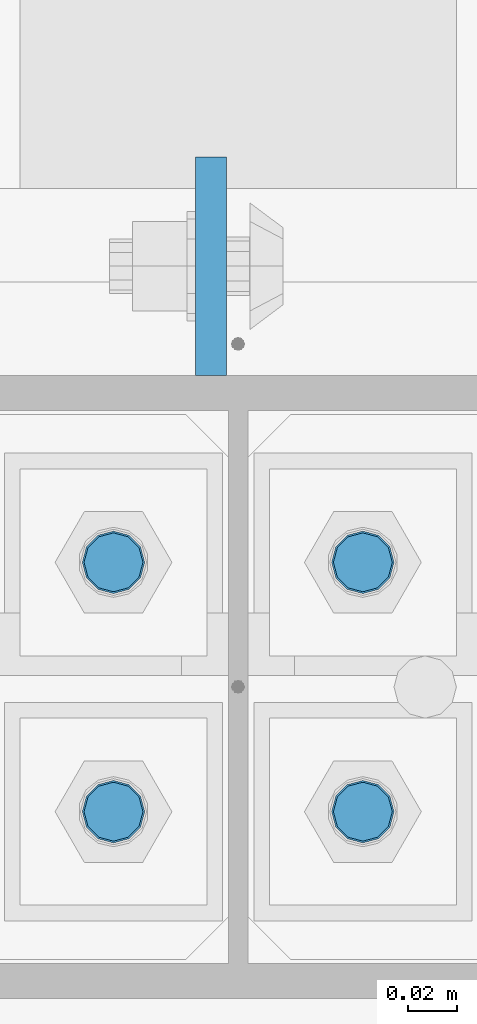
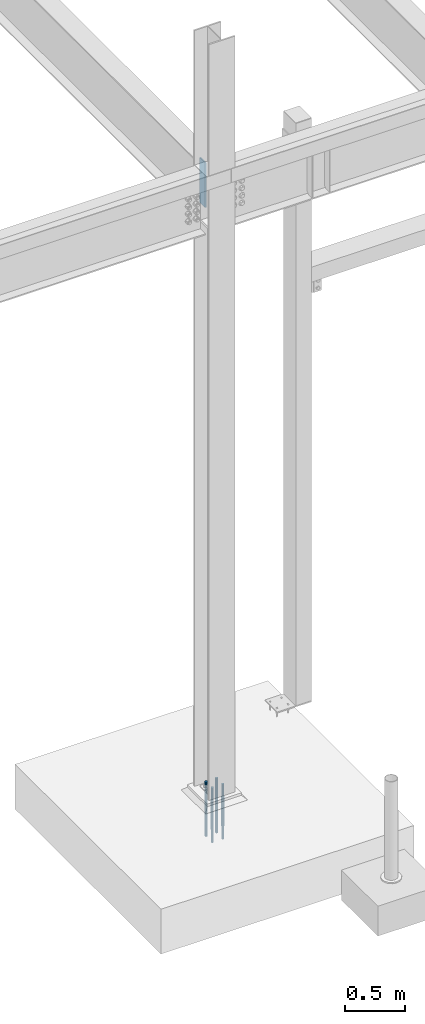
# One storey, part 1561 of 3843: 5 columns, 2 elements without a shape of their own.
"""IFC2X3 building model written with IfcOpenShell, lengths in millimetres."""

from ifc_helpers import new_model, si_unit, frame, origin_with_axes, place, context, subcontext, project, spatial, faceted_brep, material, type_object, element, aggregate, save


model = new_model("IFC2X3")

# Units and contexts
model_context = context("Model", 3, precision=1e-05, world=origin_with_axes())
body_context = subcontext(model_context, "Body", "Model", "MODEL_VIEW")
ifc_project = project(units=[si_unit("LENGTHUNIT", "METRE", prefix="MILLI"), si_unit("AREAUNIT", "SQUARE_METRE"), si_unit("VOLUMEUNIT", "CUBIC_METRE"), si_unit("MASSUNIT", "GRAM", prefix="KILO"), si_unit("TIMEUNIT", "SECOND"), si_unit("PLANEANGLEUNIT", "RADIAN"), si_unit("SOLIDANGLEUNIT", "STERADIAN"), si_unit("THERMODYNAMICTEMPERATUREUNIT", "DEGREE_CELSIUS"), si_unit("LUMINOUSINTENSITYUNIT", "LUMEN")], contexts=[model_context])

# Site, building, storey
site_placement = place(None, origin_with_axes())
site = spatial("IfcSite", under=ifc_project, at=site_placement, CompositionType="ELEMENT")
building_placement = place(site_placement, origin_with_axes())
building = spatial("IfcBuilding", under=site, at=building_placement, Name="Undefined", CompositionType="ELEMENT")
storey_placement = place(building_placement, origin_with_axes())
storey = spatial("IfcBuildingStorey", under=building, at=storey_placement, Name="Undefined", CompositionType="ELEMENT", Elevation=0.0)

# Assembly, columns
assembly_1_placement = place(storey_placement, origin_with_axes())
assembly_1 = element("IfcElementAssembly", 1, at=assembly_1_placement, inside=storey, Name="TEMPLATE", AssemblyPlace="NOTDEFINED", PredefinedType="RIGID_FRAME")
ifc_material_1 = material(Name="Undefined/F1554-GR.55")
column_type_1 = type_object("IfcColumnType", PredefinedType="NOTDEFINED")
column_1_placement = place(assembly_1_placement, frame((15189.2, 89065.1, 30022.8), z_axis=(0.0, -1.0, 0.0), x_axis=(0.0, 0.0, -1.0)))
column_1 = element("IfcColumn", 2, at=column_1_placement, type_object=column_type_1, material=ifc_material_1, Name="ANCHOR_ROD", context=body_context, shape_type="Brep", body=[
    faceted_brep([(-127.0, -10.3923048454162, 6.0), (-127.0, -6.0, 10.3923048454126), (-127.0, 0.0, 12.0), (-127.0, 6.0, 10.3923048454126), (-127.0, 10.3923048454162, 6.0), (-127.0, 12.0, 0.0), (-127.0, 10.3923048454162, -6.0), (-127.0, 6.0, -10.3923048454126), (-127.0, 0.0, -12.0), (-127.0, -6.0, -10.3923048454126), (-127.0, -10.3923048454162, -6.0), (-127.0, -12.0, 0.0), (0.0, 12.0, 0.0), (0.0, 10.3923048454162, -6.0), (0.0, 6.0, -10.3923048454126), (0.0, 0.0, -12.0), (0.0, -6.0, -10.3923048454126), (0.0, -10.3923048454162, -6.0), (0.0, -12.0, 0.0), (0.0, -10.3923048454162, 6.0), (0.0, -6.0, 10.3923048454126), (0.0, 0.0, 12.0), (0.0, 6.0, 10.3923048454126), (0.0, 10.3923048454162, 6.0), (0.0, -10.9985226280696, 6.34999999999854), (0.0, -6.35000000000582, 10.9985226280623), (0.0, 0.0, 12.6999999999971), (0.0, 6.35000000000582, 10.9985226280623), (0.0, 10.9985226280696, 6.34999999999854), (0.0, 12.6999999999971, 0.0), (0.0, 10.9985226280696, -6.34999999999854), (0.0, 6.35000000000582, -10.9985226280623), (0.0, 0.0, -12.6999999999971), (0.0, -6.35000000000582, -10.9985226280623), (0.0, -10.9985226280696, -6.34999999999854), (0.0, -12.6999999999971, 0.0), (304.799999999999, -12.6999999999971, 0.0), (304.799999999999, -10.9985226280623, 6.35000000000036), (304.799999999999, -6.34999999999854, 10.9985226280623), (304.799999999999, 0.0, 12.7000000000007), (304.799999999999, 6.34999999999854, 10.9985226280623), (304.799999999999, 10.9985226280623, 6.35000000000036), (304.799999999999, 12.6999999999971, 0.0), (304.799999999999, 10.9985226280623, -6.35000000000036), (304.799999999999, 6.34999999999854, -10.9985226280623), (304.799999999999, 0.0, -12.7000000000007), (304.799999999999, -6.34999999999854, -10.9985226280623), (304.799999999999, -10.9985226280623, -6.35000000000036), (304.799999999999, -6.0, 10.3923048454126), (304.799999999999, 0.0, 12.0), (304.799999999999, 6.0, 10.3923048454126), (304.799999999999, 10.3923048454162, 6.0), (304.799999999999, 12.0, 0.0), (304.799999999999, 10.3923048454162, -6.0), (304.799999999999, 6.0, -10.3923048454126), (304.799999999999, 0.0, -12.0), (304.799999999999, -6.0, -10.3923048454126), (304.799999999999, -10.3923048454162, -6.0), (304.799999999999, -12.0, 0.0), (304.799999999999, -10.3923048454162, 6.0), (431.799999999999, -6.0, -10.3923048454126), (431.799999999999, 0.0, -12.0), (431.799999999999, 6.0, -10.3923048454126), (431.799999999999, 10.3923048454162, -6.0), (431.799999999999, 12.0, 0.0), (431.799999999999, 10.3923048454162, 6.0), (431.799999999999, 6.0, 10.3923048454126), (431.799999999999, 0.0, 12.0), (431.799999999999, -6.0, 10.3923048454126), (431.799999999999, -10.3923048454162, 6.0), (431.799999999999, -12.0, 0.0), (431.799999999999, -10.3923048454162, -6.0)], [[[0, 1, 2, 3, 4, 5, 6, 7, 8, 9, 10, 11]], [[6, 5, 12, 13]], [[7, 6, 13, 14]], [[8, 7, 14, 15]], [[9, 8, 15, 16]], [[10, 9, 16, 17]], [[11, 10, 17, 18]], [[0, 11, 18, 19]], [[1, 0, 19, 20]], [[2, 1, 20, 21]], [[3, 2, 21, 22]], [[4, 3, 22, 23]], [[5, 4, 23, 12]], [[24, 25, 26, 27, 28, 29, 30, 31, 32, 33, 34, 35], [22, 21, 20, 19, 18, 17, 16, 15, 14, 13, 12, 23]], [[24, 35, 36, 37]], [[25, 24, 37, 38]], [[26, 25, 38, 39]], [[27, 26, 39, 40]], [[28, 27, 40, 41]], [[29, 28, 41, 42]], [[30, 29, 42, 43]], [[31, 30, 43, 44]], [[32, 31, 44, 45]], [[33, 32, 45, 46]], [[34, 33, 46, 47]], [[35, 34, 47, 36]], [[46, 45, 44, 43, 42, 41, 40, 39, 38, 37, 36, 47], [48, 49, 50, 51, 52, 53, 54, 55, 56, 57, 58, 59]], [[60, 61, 62, 63, 64, 65, 66, 67, 68, 69, 70, 71]], [[68, 67, 49, 48]], [[69, 68, 48, 59]], [[70, 69, 59, 58]], [[71, 70, 58, 57]], [[60, 71, 57, 56]], [[61, 60, 56, 55]], [[62, 61, 55, 54]], [[63, 62, 54, 53]], [[64, 63, 53, 52]], [[65, 64, 52, 51]], [[66, 65, 51, 50]], [[67, 66, 50, 49]]]),
])
column_2_placement = place(assembly_1_placement, frame((15290.8, 89065.1, 30022.8), z_axis=(0.0, 1.0, 0.0), x_axis=(0.0, 0.0, -1.0)))
column_2 = element("IfcColumn", 3, at=column_2_placement, type_object=column_type_1, material=ifc_material_1, Name="ANCHOR_ROD", context=body_context, shape_type="Brep", body=[
    faceted_brep([(-127.0, -10.3923048454162, 6.0), (-127.0, -6.0, 10.3923048454126), (-127.0, 0.0, 12.0), (-127.0, 6.0, 10.3923048454126), (-127.0, 10.3923048454162, 6.0), (-127.0, 12.0, 0.0), (-127.0, 10.3923048454162, -6.0), (-127.0, 6.0, -10.3923048454126), (-127.0, 0.0, -12.0), (-127.0, -6.0, -10.3923048454126), (-127.0, -10.3923048454162, -6.0), (-127.0, -12.0, 0.0), (0.0, 12.0, 0.0), (0.0, 10.3923048454162, -6.0), (0.0, 6.0, -10.3923048454126), (0.0, 0.0, -12.0), (0.0, -6.0, -10.3923048454126), (0.0, -10.3923048454162, -6.0), (0.0, -12.0, 0.0), (0.0, -10.3923048454162, 6.0), (0.0, -6.0, 10.3923048454126), (0.0, 0.0, 12.0), (0.0, 6.0, 10.3923048454126), (0.0, 10.3923048454162, 6.0), (0.0, -10.9985226280696, 6.34999999999854), (0.0, -6.35000000000582, 10.9985226280623), (0.0, 0.0, 12.6999999999971), (0.0, 6.35000000000582, 10.9985226280623), (0.0, 10.9985226280696, 6.34999999999854), (0.0, 12.6999999999971, 0.0), (0.0, 10.9985226280696, -6.34999999999854), (0.0, 6.35000000000582, -10.9985226280623), (0.0, 0.0, -12.6999999999971), (0.0, -6.35000000000582, -10.9985226280623), (0.0, -10.9985226280696, -6.34999999999854), (0.0, -12.6999999999971, 0.0), (304.799999999999, -12.6999999999971, 0.0), (304.799999999999, -10.9985226280623, 6.35000000000036), (304.799999999999, -6.34999999999854, 10.9985226280623), (304.799999999999, 0.0, 12.7000000000007), (304.799999999999, 6.34999999999854, 10.9985226280623), (304.799999999999, 10.9985226280623, 6.35000000000036), (304.799999999999, 12.6999999999971, 0.0), (304.799999999999, 10.9985226280623, -6.35000000000036), (304.799999999999, 6.34999999999854, -10.9985226280623), (304.799999999999, 0.0, -12.7000000000007), (304.799999999999, -6.34999999999854, -10.9985226280623), (304.799999999999, -10.9985226280623, -6.35000000000036), (304.799999999999, -6.0, 10.3923048454126), (304.799999999999, 0.0, 12.0), (304.799999999999, 6.0, 10.3923048454126), (304.799999999999, 10.3923048454162, 6.0), (304.799999999999, 12.0, 0.0), (304.799999999999, 10.3923048454162, -6.0), (304.799999999999, 6.0, -10.3923048454126), (304.799999999999, 0.0, -12.0), (304.799999999999, -6.0, -10.3923048454126), (304.799999999999, -10.3923048454162, -6.0), (304.799999999999, -12.0, 0.0), (304.799999999999, -10.3923048454162, 6.0), (431.799999999999, -6.0, -10.3923048454126), (431.799999999999, 0.0, -12.0), (431.799999999999, 6.0, -10.3923048454126), (431.799999999999, 10.3923048454162, -6.0), (431.799999999999, 12.0, 0.0), (431.799999999999, 10.3923048454162, 6.0), (431.799999999999, 6.0, 10.3923048454126), (431.799999999999, 0.0, 12.0), (431.799999999999, -6.0, 10.3923048454126), (431.799999999999, -10.3923048454162, 6.0), (431.799999999999, -12.0, 0.0), (431.799999999999, -10.3923048454162, -6.0)], [[[0, 1, 2, 3, 4, 5, 6, 7, 8, 9, 10, 11]], [[6, 5, 12, 13]], [[7, 6, 13, 14]], [[8, 7, 14, 15]], [[9, 8, 15, 16]], [[10, 9, 16, 17]], [[11, 10, 17, 18]], [[0, 11, 18, 19]], [[1, 0, 19, 20]], [[2, 1, 20, 21]], [[3, 2, 21, 22]], [[4, 3, 22, 23]], [[5, 4, 23, 12]], [[24, 25, 26, 27, 28, 29, 30, 31, 32, 33, 34, 35], [22, 21, 20, 19, 18, 17, 16, 15, 14, 13, 12, 23]], [[24, 35, 36, 37]], [[25, 24, 37, 38]], [[26, 25, 38, 39]], [[27, 26, 39, 40]], [[28, 27, 40, 41]], [[29, 28, 41, 42]], [[30, 29, 42, 43]], [[31, 30, 43, 44]], [[32, 31, 44, 45]], [[33, 32, 45, 46]], [[34, 33, 46, 47]], [[35, 34, 47, 36]], [[46, 45, 44, 43, 42, 41, 40, 39, 38, 37, 36, 47], [48, 49, 50, 51, 52, 53, 54, 55, 56, 57, 58, 59]], [[60, 61, 62, 63, 64, 65, 66, 67, 68, 69, 70, 71]], [[68, 67, 49, 48]], [[69, 68, 48, 59]], [[70, 69, 59, 58]], [[71, 70, 58, 57]], [[60, 71, 57, 56]], [[61, 60, 56, 55]], [[62, 61, 55, 54]], [[63, 62, 54, 53]], [[64, 63, 53, 52]], [[65, 64, 52, 51]], [[66, 65, 51, 50]], [[67, 66, 50, 49]]]),
])
column_3_placement = place(assembly_1_placement, frame((15189.2, 89166.7, 30022.8), z_axis=(0.0, -1.0, 0.0), x_axis=(0.0, 0.0, -1.0)))
column_3 = element("IfcColumn", 4, at=column_3_placement, type_object=column_type_1, material=ifc_material_1, Name="ANCHOR_ROD", context=body_context, shape_type="Brep", body=[
    faceted_brep([(-127.0, -10.3923048454162, 6.0), (-127.0, -6.0, 10.3923048454126), (-127.0, 0.0, 12.0), (-127.0, 6.0, 10.3923048454126), (-127.0, 10.3923048454162, 6.0), (-127.0, 12.0, 0.0), (-127.0, 10.3923048454162, -6.0), (-127.0, 6.0, -10.3923048454126), (-127.0, 0.0, -12.0), (-127.0, -6.0, -10.3923048454126), (-127.0, -10.3923048454162, -6.0), (-127.0, -12.0, 0.0), (0.0, 12.0, 0.0), (0.0, 10.3923048454162, -6.0), (0.0, 6.0, -10.3923048454126), (0.0, 0.0, -12.0), (0.0, -6.0, -10.3923048454126), (0.0, -10.3923048454162, -6.0), (0.0, -12.0, 0.0), (0.0, -10.3923048454162, 6.0), (0.0, -6.0, 10.3923048454126), (0.0, 0.0, 12.0), (0.0, 6.0, 10.3923048454126), (0.0, 10.3923048454162, 6.0), (0.0, -10.9985226280696, 6.34999999999854), (0.0, -6.35000000000582, 10.9985226280623), (0.0, 0.0, 12.6999999999971), (0.0, 6.35000000000582, 10.9985226280623), (0.0, 10.9985226280696, 6.34999999999854), (0.0, 12.6999999999971, 0.0), (0.0, 10.9985226280696, -6.34999999999854), (0.0, 6.35000000000582, -10.9985226280623), (0.0, 0.0, -12.6999999999971), (0.0, -6.35000000000582, -10.9985226280623), (0.0, -10.9985226280696, -6.34999999999854), (0.0, -12.6999999999971, 0.0), (304.799999999999, -12.6999999999971, 0.0), (304.799999999999, -10.9985226280623, 6.35000000000036), (304.799999999999, -6.34999999999854, 10.9985226280623), (304.799999999999, 0.0, 12.7000000000007), (304.799999999999, 6.34999999999854, 10.9985226280623), (304.799999999999, 10.9985226280623, 6.35000000000036), (304.799999999999, 12.6999999999971, 0.0), (304.799999999999, 10.9985226280623, -6.35000000000036), (304.799999999999, 6.34999999999854, -10.9985226280623), (304.799999999999, 0.0, -12.7000000000007), (304.799999999999, -6.34999999999854, -10.9985226280623), (304.799999999999, -10.9985226280623, -6.35000000000036), (304.799999999999, -6.0, 10.3923048454126), (304.799999999999, 0.0, 12.0), (304.799999999999, 6.0, 10.3923048454126), (304.799999999999, 10.3923048454162, 6.0), (304.799999999999, 12.0, 0.0), (304.799999999999, 10.3923048454162, -6.0), (304.799999999999, 6.0, -10.3923048454126), (304.799999999999, 0.0, -12.0), (304.799999999999, -6.0, -10.3923048454126), (304.799999999999, -10.3923048454162, -6.0), (304.799999999999, -12.0, 0.0), (304.799999999999, -10.3923048454162, 6.0), (431.799999999999, -6.0, -10.3923048454126), (431.799999999999, 0.0, -12.0), (431.799999999999, 6.0, -10.3923048454126), (431.799999999999, 10.3923048454162, -6.0), (431.799999999999, 12.0, 0.0), (431.799999999999, 10.3923048454162, 6.0), (431.799999999999, 6.0, 10.3923048454126), (431.799999999999, 0.0, 12.0), (431.799999999999, -6.0, 10.3923048454126), (431.799999999999, -10.3923048454162, 6.0), (431.799999999999, -12.0, 0.0), (431.799999999999, -10.3923048454162, -6.0)], [[[0, 1, 2, 3, 4, 5, 6, 7, 8, 9, 10, 11]], [[6, 5, 12, 13]], [[7, 6, 13, 14]], [[8, 7, 14, 15]], [[9, 8, 15, 16]], [[10, 9, 16, 17]], [[11, 10, 17, 18]], [[0, 11, 18, 19]], [[1, 0, 19, 20]], [[2, 1, 20, 21]], [[3, 2, 21, 22]], [[4, 3, 22, 23]], [[5, 4, 23, 12]], [[24, 25, 26, 27, 28, 29, 30, 31, 32, 33, 34, 35], [22, 21, 20, 19, 18, 17, 16, 15, 14, 13, 12, 23]], [[24, 35, 36, 37]], [[25, 24, 37, 38]], [[26, 25, 38, 39]], [[27, 26, 39, 40]], [[28, 27, 40, 41]], [[29, 28, 41, 42]], [[30, 29, 42, 43]], [[31, 30, 43, 44]], [[32, 31, 44, 45]], [[33, 32, 45, 46]], [[34, 33, 46, 47]], [[35, 34, 47, 36]], [[46, 45, 44, 43, 42, 41, 40, 39, 38, 37, 36, 47], [48, 49, 50, 51, 52, 53, 54, 55, 56, 57, 58, 59]], [[60, 61, 62, 63, 64, 65, 66, 67, 68, 69, 70, 71]], [[68, 67, 49, 48]], [[69, 68, 48, 59]], [[70, 69, 59, 58]], [[71, 70, 58, 57]], [[60, 71, 57, 56]], [[61, 60, 56, 55]], [[62, 61, 55, 54]], [[63, 62, 54, 53]], [[64, 63, 53, 52]], [[65, 64, 52, 51]], [[66, 65, 51, 50]], [[67, 66, 50, 49]]]),
])
column_4_placement = place(assembly_1_placement, frame((15290.8, 89166.7, 30022.8), z_axis=(0.0, 1.0, 0.0), x_axis=(0.0, 0.0, -1.0)))
column_4 = element("IfcColumn", 5, at=column_4_placement, type_object=column_type_1, material=ifc_material_1, Name="ANCHOR_ROD", context=body_context, shape_type="Brep", body=[
    faceted_brep([(-127.0, -10.3923048454162, 6.0), (-127.0, -6.0, 10.3923048454126), (-127.0, 0.0, 12.0), (-127.0, 6.0, 10.3923048454126), (-127.0, 10.3923048454162, 6.0), (-127.0, 12.0, 0.0), (-127.0, 10.3923048454162, -6.0), (-127.0, 6.0, -10.3923048454126), (-127.0, 0.0, -12.0), (-127.0, -6.0, -10.3923048454126), (-127.0, -10.3923048454162, -6.0), (-127.0, -12.0, 0.0), (0.0, 12.0, 0.0), (0.0, 10.3923048454162, -6.0), (0.0, 6.0, -10.3923048454126), (0.0, 0.0, -12.0), (0.0, -6.0, -10.3923048454126), (0.0, -10.3923048454162, -6.0), (0.0, -12.0, 0.0), (0.0, -10.3923048454162, 6.0), (0.0, -6.0, 10.3923048454126), (0.0, 0.0, 12.0), (0.0, 6.0, 10.3923048454126), (0.0, 10.3923048454162, 6.0), (0.0, -10.9985226280696, 6.34999999999854), (0.0, -6.35000000000582, 10.9985226280623), (0.0, 0.0, 12.6999999999971), (0.0, 6.35000000000582, 10.9985226280623), (0.0, 10.9985226280696, 6.34999999999854), (0.0, 12.6999999999971, 0.0), (0.0, 10.9985226280696, -6.34999999999854), (0.0, 6.35000000000582, -10.9985226280623), (0.0, 0.0, -12.6999999999971), (0.0, -6.35000000000582, -10.9985226280623), (0.0, -10.9985226280696, -6.34999999999854), (0.0, -12.6999999999971, 0.0), (304.799999999999, -12.6999999999971, 0.0), (304.799999999999, -10.9985226280623, 6.35000000000036), (304.799999999999, -6.34999999999854, 10.9985226280623), (304.799999999999, 0.0, 12.7000000000007), (304.799999999999, 6.34999999999854, 10.9985226280623), (304.799999999999, 10.9985226280623, 6.35000000000036), (304.799999999999, 12.6999999999971, 0.0), (304.799999999999, 10.9985226280623, -6.35000000000036), (304.799999999999, 6.34999999999854, -10.9985226280623), (304.799999999999, 0.0, -12.7000000000007), (304.799999999999, -6.34999999999854, -10.9985226280623), (304.799999999999, -10.9985226280623, -6.35000000000036), (304.799999999999, -6.0, 10.3923048454126), (304.799999999999, 0.0, 12.0), (304.799999999999, 6.0, 10.3923048454126), (304.799999999999, 10.3923048454162, 6.0), (304.799999999999, 12.0, 0.0), (304.799999999999, 10.3923048454162, -6.0), (304.799999999999, 6.0, -10.3923048454126), (304.799999999999, 0.0, -12.0), (304.799999999999, -6.0, -10.3923048454126), (304.799999999999, -10.3923048454162, -6.0), (304.799999999999, -12.0, 0.0), (304.799999999999, -10.3923048454162, 6.0), (431.799999999999, -6.0, -10.3923048454126), (431.799999999999, 0.0, -12.0), (431.799999999999, 6.0, -10.3923048454126), (431.799999999999, 10.3923048454162, -6.0), (431.799999999999, 12.0, 0.0), (431.799999999999, 10.3923048454162, 6.0), (431.799999999999, 6.0, 10.3923048454126), (431.799999999999, 0.0, 12.0), (431.799999999999, -6.0, 10.3923048454126), (431.799999999999, -10.3923048454162, 6.0), (431.799999999999, -12.0, 0.0), (431.799999999999, -10.3923048454162, -6.0)], [[[0, 1, 2, 3, 4, 5, 6, 7, 8, 9, 10, 11]], [[6, 5, 12, 13]], [[7, 6, 13, 14]], [[8, 7, 14, 15]], [[9, 8, 15, 16]], [[10, 9, 16, 17]], [[11, 10, 17, 18]], [[0, 11, 18, 19]], [[1, 0, 19, 20]], [[2, 1, 20, 21]], [[3, 2, 21, 22]], [[4, 3, 22, 23]], [[5, 4, 23, 12]], [[24, 25, 26, 27, 28, 29, 30, 31, 32, 33, 34, 35], [22, 21, 20, 19, 18, 17, 16, 15, 14, 13, 12, 23]], [[24, 35, 36, 37]], [[25, 24, 37, 38]], [[26, 25, 38, 39]], [[27, 26, 39, 40]], [[28, 27, 40, 41]], [[29, 28, 41, 42]], [[30, 29, 42, 43]], [[31, 30, 43, 44]], [[32, 31, 44, 45]], [[33, 32, 45, 46]], [[34, 33, 46, 47]], [[35, 34, 47, 36]], [[46, 45, 44, 43, 42, 41, 40, 39, 38, 37, 36, 47], [48, 49, 50, 51, 52, 53, 54, 55, 56, 57, 58, 59]], [[60, 61, 62, 63, 64, 65, 66, 67, 68, 69, 70, 71]], [[68, 67, 49, 48]], [[69, 68, 48, 59]], [[70, 69, 59, 58]], [[71, 70, 58, 57]], [[60, 71, 57, 56]], [[61, 60, 56, 55]], [[62, 61, 55, 54]], [[63, 62, 54, 53]], [[64, 63, 53, 52]], [[65, 64, 52, 51]], [[66, 65, 51, 50]], [[67, 66, 50, 49]]]),
])
aggregate(assembly_1, [column_1, column_2, column_3, column_4])

# Assembly, column
assembly_2_placement = place(storey_placement, origin_with_axes())
assembly_2 = element("IfcElementAssembly", 6, at=assembly_2_placement, inside=storey, Name="COLUMN", AssemblyPlace="NOTDEFINED", PredefinedType="RIGID_FRAME")
ifc_material_2 = material(Name="STEEL/A572-50")
column_type_2 = type_object("IfcColumnType", PredefinedType="NOTDEFINED")
column_5_placement = place(assembly_2_placement, frame((15228.8879999161, 89287.35, 35941.0), z_axis=(0.0, -1.0, 0.0), x_axis=(0.0, 0.0, 1.0)))
column_5 = element("IfcColumn", 7, at=column_5_placement, type_object=column_type_2, material=ifc_material_2, Name="PLATE", context=body_context, shape_type="Brep", body=[
    faceted_brep([(0.0, 6.34999999999854, -44.4500000000007), (0.0, 6.34999999999854, 44.4500000000007), (457.199999999997, 6.35000000000582, 44.4499999999971), (457.199999999997, 6.35000000000582, -44.4499999999971), (0.0, -6.34999999999854, 44.4500000000007), (457.199999999997, -6.35000000000582, 44.4499999999971), (0.0, -6.34999999999854, -44.4500000000007), (457.199999999997, -6.35000000000582, -44.4499999999971)], [[[0, 1, 2, 3]], [[1, 4, 5, 2]], [[4, 6, 7, 5]], [[6, 0, 3, 7]], [[5, 7, 3, 2]], [[6, 4, 1, 0]]]),
])
aggregate(assembly_2, [column_5])

save(model, "model.ifc")
